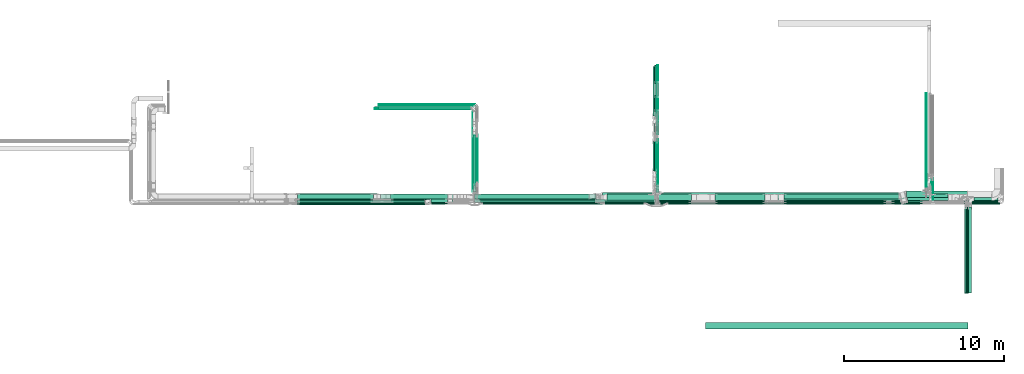
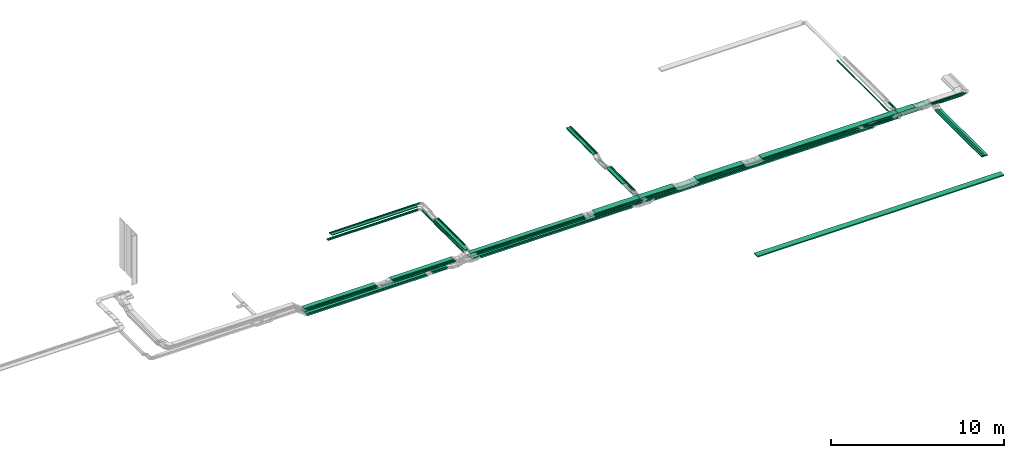
# One storey, part 2 of 27: 76 flow segments.
"""IFC2X3 building model written with IfcOpenShell, lengths in millimetres."""

from ifc_helpers import new_model, entity, si_unit, converted_unit, derived_unit, direction, frame, origin, origin_2d_with_axis, place, context, subcontext, project, spatial, rectangle, extrude, type_object, element, save


model = new_model("IFC2X3")

# Units and contexts
model_context = context("Model", 3, precision=0.01, world=origin(), true_north=direction((6.12303176911189e-17, 1.0)))
body_context = subcontext(model_context, "Body", "Model", "MODEL_VIEW")
ifc_project = project(units=[si_unit("LENGTHUNIT", "METRE", prefix="MILLI"), si_unit("AREAUNIT", "SQUARE_METRE"), si_unit("VOLUMEUNIT", "CUBIC_METRE"), converted_unit("PLANEANGLEUNIT", "DEGREE", entity("IfcRatioMeasure", 0.0174532925199433), si_unit("PLANEANGLEUNIT", "RADIAN"), dimensions=[0, 0, 0, 0, 0, 0, 0]), si_unit("MASSUNIT", "GRAM", prefix="KILO"), derived_unit("MASSDENSITYUNIT", [(si_unit("MASSUNIT", "GRAM", prefix="KILO"), 1), (si_unit("LENGTHUNIT", "METRE"), -3)]), derived_unit("MOMENTOFINERTIAUNIT", [(si_unit("LENGTHUNIT", "METRE"), 4)]), si_unit("TIMEUNIT", "SECOND"), si_unit("FREQUENCYUNIT", "HERTZ"), si_unit("THERMODYNAMICTEMPERATUREUNIT", "DEGREE_CELSIUS"), derived_unit("THERMALTRANSMITTANCEUNIT", [(si_unit("MASSUNIT", "GRAM", prefix="KILO"), 1), (si_unit("THERMODYNAMICTEMPERATUREUNIT", "KELVIN"), -1), (si_unit("TIMEUNIT", "SECOND"), -3)]), derived_unit("VOLUMETRICFLOWRATEUNIT", [(si_unit("LENGTHUNIT", "METRE"), 3), (si_unit("TIMEUNIT", "SECOND"), -1)]), derived_unit("MASSFLOWRATEUNIT", [(si_unit("MASSUNIT", "GRAM", prefix="KILO"), 1), (si_unit("TIMEUNIT", "SECOND"), -1)]), derived_unit("ROTATIONALFREQUENCYUNIT", [(si_unit("TIMEUNIT", "SECOND"), -1)]), si_unit("ELECTRICCURRENTUNIT", "AMPERE"), si_unit("ELECTRICVOLTAGEUNIT", "VOLT"), si_unit("POWERUNIT", "WATT"), si_unit("FORCEUNIT", "NEWTON", prefix="KILO"), si_unit("ILLUMINANCEUNIT", "LUX"), si_unit("LUMINOUSFLUXUNIT", "LUMEN"), si_unit("LUMINOUSINTENSITYUNIT", "CANDELA"), derived_unit("USERDEFINED", [(si_unit("MASSUNIT", "GRAM", prefix="KILO"), -1), (si_unit("LENGTHUNIT", "METRE"), -2), (si_unit("TIMEUNIT", "SECOND"), 3), (si_unit("LUMINOUSFLUXUNIT", "LUMEN"), 1)]), derived_unit("LINEARVELOCITYUNIT", [(si_unit("LENGTHUNIT", "METRE"), 1), (si_unit("TIMEUNIT", "SECOND"), -1)]), si_unit("PRESSUREUNIT", "PASCAL"), derived_unit("USERDEFINED", [(si_unit("LENGTHUNIT", "METRE"), -2), (si_unit("MASSUNIT", "GRAM", prefix="KILO"), 1), (si_unit("TIMEUNIT", "SECOND"), -2)]), derived_unit("LINEARFORCEUNIT", [(si_unit("MASSUNIT", "GRAM", prefix="KILO"), 1), (si_unit("LENGTHUNIT", "METRE"), 1), (si_unit("TIMEUNIT", "SECOND"), -2), (si_unit("LENGTHUNIT", "METRE"), -1)]), derived_unit("PLANARFORCEUNIT", [(si_unit("MASSUNIT", "GRAM", prefix="KILO"), 1), (si_unit("LENGTHUNIT", "METRE"), 1), (si_unit("TIMEUNIT", "SECOND"), -2), (si_unit("LENGTHUNIT", "METRE"), -2)])], contexts=[model_context])

# Site, building, storey
site_placement = place(None, origin())
site = spatial("IfcSite", under=ifc_project, at=site_placement, CompositionType="ELEMENT")
building_placement = place(site_placement, origin())
building = spatial("IfcBuilding", under=site, at=building_placement, CompositionType="ELEMENT")
storey_placement = place(building_placement, origin())
storey = spatial("IfcBuildingStorey", under=building, at=storey_placement, CompositionType="ELEMENT", Elevation=0.0)

# Flow segments
cable_carrier_segment_type = type_object("IfcCableCarrierSegmentType", PredefinedType="CABLETRAYSEGMENT")
flow_segment_1_placement = place(storey_placement, frame((54929.8, 8300.0, 2850.0)))
element("IfcFlowSegment", 1, at=flow_segment_1_placement, inside=storey, type_object=cable_carrier_segment_type, context=body_context, shape_type="SweptSolid", body=[
    extrude(rectangle(XDim=6370.08732356079, YDim=99.9999999999989, at=origin_2d_with_axis()), frame((3185.04, 50.0, 0.0), z_axis=(0.0, 0.0, 1.0), x_axis=(-1.0, 0.0, 0.0)), (0.0, 0.0, 1.0), 49.9999999999995),
])
flow_segment_2_placement = place(storey_placement, frame((47132.17, 8410.0, 2850.0)))
element("IfcFlowSegment", 2, at=flow_segment_2_placement, inside=storey, type_object=cable_carrier_segment_type, context=body_context, shape_type="SweptSolid", body=[
    extrude(rectangle(XDim=2006.37627300281, YDim=100.000000000001, at=origin_2d_with_axis()), frame((1003.19, 50.0, 0.0)), (0.0, 0.0, 1.0), 49.9999999999995),
])
flow_segment_3_placement = place(storey_placement, frame((46843.18, 8520.0, 2850.0)))
element("IfcFlowSegment", 3, at=flow_segment_3_placement, inside=storey, type_object=cable_carrier_segment_type, context=body_context, shape_type="SweptSolid", body=[
    extrude(rectangle(XDim=2295.36020532801, YDim=400.0, at=origin_2d_with_axis()), frame((1147.68, 200.0, 0.0)), (0.0, 0.0, 1.0), 49.9999999999995),
])
flow_segment_4_placement = place(storey_placement, frame((35521.11, 8620.0, 2600.0)))
element("IfcFlowSegment", 4, at=flow_segment_4_placement, inside=storey, type_object=cable_carrier_segment_type, context=body_context, shape_type="SweptSolid", body=[
    extrude(rectangle(XDim=7219.09376803744, YDim=299.999999999999, at=origin_2d_with_axis()), frame((3609.55, 150.0, 0.0)), (0.0, 0.0, 1.0), 100.0),
])
flow_segment_5_placement = place(storey_placement, frame((24527.31, 8570.0, 2600.0)))
element("IfcFlowSegment", 5, at=flow_segment_5_placement, inside=storey, type_object=cable_carrier_segment_type, context=body_context, shape_type="SweptSolid", body=[
    extrude(rectangle(XDim=4983.74700171906, YDim=400.0, at=origin_2d_with_axis()), frame((2491.87, 200.0, 0.0), z_axis=(0.0, 0.0, 1.0), x_axis=(-1.0, 0.0, 0.0)), (0.0, 0.0, 1.0), 100.0),
])
flow_segment_6_placement = place(storey_placement, frame((63792.18, 9272.4, 2600.0)))
element("IfcFlowSegment", 6, at=flow_segment_6_placement, inside=storey, type_object=cable_carrier_segment_type, context=body_context, shape_type="SweptSolid", body=[
    extrude(rectangle(XDim=5940.0, YDim=50.000000000006, at=origin_2d_with_axis()), frame((25.0, 2970.0, 0.0), z_axis=(0.0, 0.0, 1.0), x_axis=(0.0, -1.0, 0.0)), (0.0, 0.0, 1.0), 49.9999999999995),
])
flow_segment_7_placement = place(storey_placement, frame((62655.57, 8400.0, 2600.0)))
element("IfcFlowSegment", 7, at=flow_segment_7_placement, inside=storey, type_object=cable_carrier_segment_type, context=body_context, shape_type="SweptSolid", body=[
    extrude(rectangle(XDim=1271.610584688, YDim=99.9999999999989, at=origin_2d_with_axis()), frame((635.81, 50.0, 0.0)), (0.0, 0.0, 1.0), 100.0),
])
flow_segment_8_placement = place(storey_placement, frame((46898.17, 8410.17, 2600.0)))
element("IfcFlowSegment", 8, at=flow_segment_8_placement, inside=storey, type_object=cable_carrier_segment_type, context=body_context, shape_type="SweptSolid", body=[
    extrude(rectangle(XDim=15296.8333798477, YDim=200.0, at=origin_2d_with_axis()), frame((7648.42, 100.0, 0.0), z_axis=(0.0, 0.0, 1.0), x_axis=(-1.0, 0.0, 0.0)), (0.0, 0.0, 1.0), 100.0),
])
flow_segment_9_placement = place(storey_placement, frame((47045.82, 8620.17, 2600.0)))
element("IfcFlowSegment", 9, at=flow_segment_9_placement, inside=storey, type_object=cable_carrier_segment_type, context=body_context, shape_type="SweptSolid", body=[
    extrude(rectangle(XDim=15060.2769853209, YDim=400.0, at=origin_2d_with_axis()), frame((7530.14, 200.0, 0.0), z_axis=(0.0, 0.0, 1.0), x_axis=(-1.0, 0.0, 0.0)), (0.0, 0.0, 1.0), 100.0),
])
flow_segment_10_placement = place(storey_placement, frame((62577.11, 8724.33, 2600.0)))
element("IfcFlowSegment", 10, at=flow_segment_10_placement, inside=storey, type_object=cable_carrier_segment_type, context=body_context, shape_type="SweptSolid", body=[
    extrude(rectangle(XDim=1239.07857285351, YDim=400.0, at=origin_2d_with_axis()), frame((619.54, 200.0, 0.0)), (0.0, 0.0, 1.0), 100.0),
])
flow_segment_11_placement = place(storey_placement, frame((62638.62, 8514.33, 2600.0)))
element("IfcFlowSegment", 11, at=flow_segment_11_placement, inside=storey, type_object=cable_carrier_segment_type, context=body_context, shape_type="SweptSolid", body=[
    extrude(rectangle(XDim=1418.74753721558, YDim=200.0, at=origin_2d_with_axis()), frame((709.37, 100.0, 0.0)), (0.0, 0.0, 1.0), 100.0),
])
flow_segment_12_placement = place(storey_placement, frame((64058.17, 8514.33, 2600.0)))
element("IfcFlowSegment", 12, at=flow_segment_12_placement, inside=storey, type_object=cable_carrier_segment_type, context=body_context, shape_type="SweptSolid", body=[
    extrude(rectangle(XDim=1550.00000000001, YDim=200.0, at=origin_2d_with_axis()), frame((775.0, 100.0, 0.0)), (0.0, 0.0, 1.0), 100.000000000001),
])
flow_segment_13_placement = place(storey_placement, frame((66145.26, 8410.0, 2850.0)))
element("IfcFlowSegment", 13, at=flow_segment_13_placement, inside=storey, type_object=cable_carrier_segment_type, context=body_context, shape_type="SweptSolid", body=[
    extrude(rectangle(XDim=2159.75324383904, YDim=99.9999999999989, at=origin_2d_with_axis()), frame((1079.88, 50.0, 0.0), z_axis=(0.0, 0.0, 1.0), x_axis=(-1.0, 0.0, 0.0)), (0.0, 0.0, 1.0), 49.9999999999995),
])
flow_segment_14_placement = place(storey_placement, frame((64197.18, 8489.64, 2719.29)))
element("IfcFlowSegment", 14, at=flow_segment_14_placement, inside=storey, type_object=cable_carrier_segment_type, context=body_context, shape_type="SweptSolid", body=[
    extrude(rectangle(XDim=1417.59981973826, YDim=50.000000000006, at=origin_2d_with_axis()), frame((25.0, 708.8, 0.0), z_axis=(0.0, 0.0, 1.0), x_axis=(0.0, -1.0, 0.0)), (0.0, 0.0, 1.0), 50.0000000000005),
])
flow_segment_15_placement = place(storey_placement, frame((64137.18, 8409.33, 2721.0)))
element("IfcFlowSegment", 15, at=flow_segment_15_placement, inside=storey, type_object=cable_carrier_segment_type, context=body_context, shape_type="SweptSolid", body=[
    extrude(rectangle(XDim=1500.75933458754, YDim=50.000000000006, at=origin_2d_with_axis()), frame((25.0, 750.38, 0.0), z_axis=(0.0, 0.0, 1.0), x_axis=(0.0, 1.0, 0.0)), (0.0, 0.0, 1.0), 50.0000000000005),
])
flow_segment_16_placement = place(storey_placement, frame((66145.26, 8300.0, 2850.0)))
element("IfcFlowSegment", 16, at=flow_segment_16_placement, inside=storey, type_object=cable_carrier_segment_type, context=body_context, shape_type="SweptSolid", body=[
    extrude(rectangle(XDim=2269.75324383909, YDim=99.9999999999989, at=origin_2d_with_axis()), frame((1134.88, 50.0, 0.0), z_axis=(0.0, 0.0, 1.0), x_axis=(-1.0, 0.0, 0.0)), (0.0, 0.0, 1.0), 49.9999999999995),
])
flow_segment_17_placement = place(storey_placement, frame((46847.77, 15822.8, 2600.0)))
element("IfcFlowSegment", 17, at=flow_segment_17_placement, inside=storey, type_object=cable_carrier_segment_type, context=body_context, shape_type="SweptSolid", body=[
    extrude(rectangle(XDim=1137.0957799209, YDim=99.9999999999946, at=origin_2d_with_axis()), frame((50.0, 568.55, 0.0), z_axis=(0.0, 0.0, 1.0), x_axis=(0.0, 1.0, 0.0)), (0.0, 0.0, 1.0), 49.9999999999995),
])
for number, where in (
    (18, (47012.18, 13790.77, 2800.0)),
    (19, (46952.18, 13790.77, 2800.0)),
):
    element("IfcFlowSegment", number, at=place(storey_placement, frame(where)), inside=storey, type_object=cable_carrier_segment_type, context=body_context, shape_type="SweptSolid", body=[
        extrude(rectangle(XDim=3099.22880375789, YDim=50.000000000006, at=origin_2d_with_axis()), frame((25.0, 1549.61, 0.0), z_axis=(0.0, 0.0, 1.0), x_axis=(0.0, 1.0, 0.0)), (0.0, 0.0, 1.0), 49.9999999999995),
    ])
flow_segment_18_placement = place(storey_placement, frame((47019.82, 15822.8, 2600.0)))
element("IfcFlowSegment", 20, at=flow_segment_18_placement, inside=storey, type_object=cable_carrier_segment_type, context=body_context, shape_type="SweptSolid", body=[
    extrude(rectangle(XDim=1137.09577991943, YDim=50.000000000006, at=origin_2d_with_axis()), frame((25.0, 568.55, 0.0), z_axis=(0.0, 0.0, 1.0), x_axis=(0.0, 1.0, 0.0)), (0.0, 0.0, 1.0), 50.0000000000005),
])
flow_segment_19_placement = place(storey_placement, frame((32876.65, 8410.17, 2600.0)))
element("IfcFlowSegment", 21, at=flow_segment_19_placement, inside=storey, type_object=cable_carrier_segment_type, context=body_context, shape_type="SweptSolid", body=[
    extrude(rectangle(XDim=1039.99874618809, YDim=200.0, at=origin_2d_with_axis()), frame((520.0, 100.0, 0.0)), (0.0, 0.0, 1.0), 100.000000000001),
])
flow_segment_20_placement = place(storey_placement, frame((43583.82, 8620.17, 2600.0)))
element("IfcFlowSegment", 22, at=flow_segment_20_placement, inside=storey, type_object=cable_carrier_segment_type, context=body_context, shape_type="SweptSolid", body=[
    extrude(rectangle(XDim=3460.0, YDim=400.0, at=origin_2d_with_axis()), frame((1730.0, 200.0, 0.0), z_axis=(0.0, 0.0, 1.0), x_axis=(-1.0, 0.0, 0.0)), (0.0, 0.0, 1.0), 100.0),
])
flow_segment_21_placement = place(storey_placement, frame((47688.79, 8300.17, 2600.0)))
element("IfcFlowSegment", 23, at=flow_segment_21_placement, inside=storey, type_object=cable_carrier_segment_type, context=body_context, shape_type="SweptSolid", body=[
    extrude(rectangle(XDim=14552.3620361267, YDim=100.000000000001, at=origin_2d_with_axis()), frame((7276.18, 50.0, 0.0)), (0.0, 0.0, 1.0), 100.0),
])
flow_segment_22_placement = place(storey_placement, frame((46742.18, 13790.77, 2800.0)))
element("IfcFlowSegment", 24, at=flow_segment_22_placement, inside=storey, type_object=cable_carrier_segment_type, context=body_context, shape_type="SweptSolid", body=[
    extrude(rectangle(XDim=3099.2288037579, YDim=200.000000000007, at=origin_2d_with_axis()), frame((100.0, 1549.61, 0.0), z_axis=(0.0, 0.0, 1.0), x_axis=(0.0, 1.0, 0.0)), (0.0, 0.0, 1.0), 50.0000000000005),
])
flow_segment_23_placement = place(storey_placement, frame((43861.18, 8520.0, 2850.0)))
element("IfcFlowSegment", 25, at=flow_segment_23_placement, inside=storey, type_object=cable_carrier_segment_type, context=body_context, shape_type="SweptSolid", body=[
    extrude(rectangle(XDim=2980.00000000002, YDim=400.0, at=origin_2d_with_axis()), frame((1490.0, 200.0, 0.0), z_axis=(0.0, 0.0, 1.0), x_axis=(-1.0, 0.0, 0.0)), (0.0, 0.0, 1.0), 49.9999999999995),
])
flow_segment_24_placement = place(storey_placement, frame((35555.11, 9465.53, 2600.0)))
element("IfcFlowSegment", 26, at=flow_segment_24_placement, inside=storey, type_object=cable_carrier_segment_type, context=body_context, shape_type="SweptSolid", body=[
    extrude(rectangle(XDim=4668.46927962027, YDim=100.000000000003, at=origin_2d_with_axis()), frame((50.0, 2334.23, 0.0), z_axis=(0.0, 0.0, 1.0), x_axis=(0.0, 1.0, 0.0)), (0.0, 0.0, 1.0), 49.9999999999995),
])
flow_segment_25_placement = place(storey_placement, frame((35767.46, 9536.72, 2850.0)))
element("IfcFlowSegment", 27, at=flow_segment_25_placement, inside=storey, type_object=cable_carrier_segment_type, context=body_context, shape_type="SweptSolid", body=[
    extrude(rectangle(XDim=3095.56319386164, YDim=49.9999999999973, at=origin_2d_with_axis()), frame((25.0, 1547.78, 0.0), z_axis=(0.0, 0.0, 1.0), x_axis=(0.0, 1.0, 0.0)), (0.0, 0.0, 1.0), 50.0000000000005),
])
flow_segment_26_placement = place(storey_placement, frame((35707.46, 9536.72, 2850.0)))
element("IfcFlowSegment", 28, at=flow_segment_26_placement, inside=storey, type_object=cable_carrier_segment_type, context=body_context, shape_type="SweptSolid", body=[
    extrude(rectangle(XDim=3095.5631938618, YDim=49.9999999999973, at=origin_2d_with_axis()), frame((25.0, 1547.78, 0.0), z_axis=(0.0, 0.0, 1.0), x_axis=(0.0, -1.0, 0.0)), (0.0, 0.0, 1.0), 50.0000000000005),
])
flow_segment_27_placement = place(storey_placement, frame((35495.11, 9070.0, 2850.0)))
element("IfcFlowSegment", 29, at=flow_segment_27_placement, inside=storey, type_object=cable_carrier_segment_type, context=body_context, shape_type="SweptSolid", body=[
    extrude(rectangle(XDim=3562.28653481264, YDim=199.999999999998, at=origin_2d_with_axis()), frame((100.0, 1781.14, 0.0), z_axis=(0.0, 0.0, 1.0), x_axis=(0.0, 1.0, 0.0)), (0.0, 0.0, 1.0), 50.0000000000005),
])
flow_segment_28_placement = place(storey_placement, frame((29362.46, 14285.0, 2600.0)))
element("IfcFlowSegment", 30, at=flow_segment_28_placement, inside=storey, type_object=cable_carrier_segment_type, context=body_context, shape_type="SweptSolid", body=[
    extrude(rectangle(XDim=6041.64888445136, YDim=99.9999999999989, at=origin_2d_with_axis()), frame((3020.82, 50.0, 0.0), z_axis=(0.0, 0.0, 1.0), x_axis=(-1.0, 0.0, 0.0)), (0.0, 0.0, 1.0), 49.9999999999995),
])
flow_segment_29_placement = place(storey_placement, frame((35495.11, 9060.0, 2600.0)))
element("IfcFlowSegment", 31, at=flow_segment_29_placement, inside=storey, type_object=cable_carrier_segment_type, context=body_context, shape_type="SweptSolid", body=[
    extrude(rectangle(XDim=5013.99993893918, YDim=49.9999999999973, at=origin_2d_with_axis()), frame((25.0, 2507.0, 0.0), z_axis=(0.0, 0.0, 1.0), x_axis=(0.0, 1.0, 0.0)), (0.0, 0.0, 1.0), 50.0000000000005),
])
flow_segment_30_placement = place(storey_placement, frame((29362.46, 14225.0, 2600.0)))
element("IfcFlowSegment", 32, at=flow_segment_30_placement, inside=storey, type_object=cable_carrier_segment_type, context=body_context, shape_type="SweptSolid", body=[
    extrude(rectangle(XDim=5981.64888445141, YDim=50.0000000000016, at=origin_2d_with_axis()), frame((2990.82, 25.0, 0.0), z_axis=(0.0, 0.0, 1.0), x_axis=(-1.0, 0.0, 0.0)), (0.0, 0.0, 1.0), 49.9999999999995),
])
flow_segment_31_placement = place(storey_placement, frame((29612.46, 14495.0, 2850.0)))
element("IfcFlowSegment", 33, at=flow_segment_31_placement, inside=storey, type_object=cable_carrier_segment_type, context=body_context, shape_type="SweptSolid", body=[
    extrude(rectangle(XDim=6025.00000000003, YDim=50.0000000000016, at=origin_2d_with_axis()), frame((3012.5, 25.0, 0.0), z_axis=(0.0, 0.0, 1.0), x_axis=(-1.0, 0.0, 0.0)), (0.0, 0.0, 1.0), 50.0000000000005),
])
flow_segment_32_placement = place(storey_placement, frame((29612.46, 14435.0, 2850.0)))
element("IfcFlowSegment", 34, at=flow_segment_32_placement, inside=storey, type_object=cable_carrier_segment_type, context=body_context, shape_type="SweptSolid", body=[
    extrude(rectangle(XDim=5944.00000000003, YDim=50.0000000000016, at=origin_2d_with_axis()), frame((2972.0, 25.0, 0.0), z_axis=(0.0, 0.0, 1.0), x_axis=(-1.0, 0.0, 0.0)), (0.0, 0.0, 1.0), 50.0000000000005),
])
flow_segment_33_placement = place(storey_placement, frame((29612.46, 14225.0, 2850.0)))
element("IfcFlowSegment", 35, at=flow_segment_33_placement, inside=storey, type_object=cable_carrier_segment_type, context=body_context, shape_type="SweptSolid", body=[
    extrude(rectangle(XDim=5731.6488844514, YDim=200.000000000002, at=origin_2d_with_axis()), frame((2865.82, 100.0, 0.0), z_axis=(0.0, 0.0, 1.0), x_axis=(-1.0, 0.0, 0.0)), (0.0, 0.0, 1.0), 49.9999999999995),
])
flow_segment_34_placement = place(storey_placement, frame((30367.01, 8620.0, 2850.0)))
element("IfcFlowSegment", 36, at=flow_segment_34_placement, inside=storey, type_object=cable_carrier_segment_type, context=body_context, shape_type="SweptSolid", body=[
    extrude(rectangle(XDim=4130.35917387728, YDim=300.000000000001, at=origin_2d_with_axis()), frame((2065.18, 150.0, 0.0)), (0.0, 0.0, 1.0), 49.9999999999995),
])
flow_segment_35_placement = place(storey_placement, frame((30367.01, 8510.0, 2850.0)))
element("IfcFlowSegment", 37, at=flow_segment_35_placement, inside=storey, type_object=cable_carrier_segment_type, context=body_context, shape_type="SweptSolid", body=[
    extrude(rectangle(XDim=4130.35917387756, YDim=100.000000000001, at=origin_2d_with_axis()), frame((2065.18, 50.0, 0.0), z_axis=(0.0, 0.0, 1.0), x_axis=(-1.0, 0.0, 0.0)), (0.0, 0.0, 1.0), 50.0000000000011),
])
flow_segment_36_placement = place(storey_placement, frame((30367.01, 8400.0, 2850.0)))
element("IfcFlowSegment", 38, at=flow_segment_36_placement, inside=storey, type_object=cable_carrier_segment_type, context=body_context, shape_type="SweptSolid", body=[
    extrude(rectangle(XDim=4130.35917387749, YDim=100.000000000001, at=origin_2d_with_axis()), frame((2065.18, 50.0, 0.0), z_axis=(0.0, 0.0, 1.0), x_axis=(-1.0, 0.0, 0.0)), (0.0, 0.0, 1.0), 49.9999999999995),
])
flow_segment_37_placement = place(storey_placement, frame((50627.81, 8410.0, 2850.0)))
element("IfcFlowSegment", 39, at=flow_segment_37_placement, inside=storey, type_object=cable_carrier_segment_type, context=body_context, shape_type="SweptSolid", body=[
    extrude(rectangle(XDim=3111.50022738776, YDim=99.9999999999989, at=origin_2d_with_axis()), frame((1555.75, 50.0, 0.0), z_axis=(7.08942723260704e-08, 0.0, 1.0), x_axis=(-1.0, 0.0, 7.08942723260704e-08)), (0.0, 0.0, 1.0), 49.9999999999996),
])
flow_segment_38_placement = place(storey_placement, frame((47199.82, 8300.0, 2850.0)))
element("IfcFlowSegment", 40, at=flow_segment_38_placement, inside=storey, type_object=cable_carrier_segment_type, context=body_context, shape_type="SweptSolid", body=[
    extrude(rectangle(XDim=1938.72426175145, YDim=99.9999999999989, at=origin_2d_with_axis()), frame((969.36, 50.0, 0.0)), (0.0, 0.0, 1.0), 49.9999999999995),
])
flow_segment_39_placement = place(storey_placement, frame((47019.82, 9060.0, 2600.0)))
element("IfcFlowSegment", 41, at=flow_segment_39_placement, inside=storey, type_object=cable_carrier_segment_type, context=body_context, shape_type="SweptSolid", body=[
    extrude(rectangle(XDim=3286.61163187284, YDim=50.000000000006, at=origin_2d_with_axis()), frame((25.0, 1643.31, 0.0), z_axis=(0.0, 0.0, 1.0), x_axis=(0.0, -1.0, 0.0)), (0.0, 0.0, 1.0), 49.9999999999995),
])
flow_segment_40_placement = place(storey_placement, frame((46847.77, 9444.27, 2600.0)))
element("IfcFlowSegment", 42, at=flow_segment_40_placement, inside=storey, type_object=cable_carrier_segment_type, context=body_context, shape_type="SweptSolid", body=[
    extrude(rectangle(XDim=2902.34103191558, YDim=99.9999999999946, at=origin_2d_with_axis()), frame((50.0, 1451.17, 0.0), z_axis=(0.0, 0.0, 1.0), x_axis=(0.0, 1.0, 0.0)), (0.0, 0.0, 1.0), 49.9999999999995),
])
flow_segment_41_placement = place(storey_placement, frame((47019.82, 12660.0, 2450.0)))
element("IfcFlowSegment", 43, at=flow_segment_41_placement, inside=storey, type_object=cable_carrier_segment_type, context=body_context, shape_type="SweptSolid", body=[
    extrude(rectangle(XDim=1103.60147622474, YDim=50.000000000006, at=origin_2d_with_axis()), frame((25.0, 551.8, 0.0), z_axis=(0.0, 0.0, 1.0), x_axis=(0.0, -1.0, 0.0)), (0.0, 0.0, 1.0), 50.0000000000005),
])
flow_segment_42_placement = place(storey_placement, frame((46847.77, 12660.0, 2450.0)))
element("IfcFlowSegment", 44, at=flow_segment_42_placement, inside=storey, type_object=cable_carrier_segment_type, context=body_context, shape_type="SweptSolid", body=[
    extrude(rectangle(XDim=1103.60147622524, YDim=99.9999999999946, at=origin_2d_with_axis()), frame((50.0, 551.8, 0.0), z_axis=(0.0, 0.0, 1.0), x_axis=(0.0, -1.0, 0.0)), (0.0, 0.0, 1.0), 50.0000000000005),
])
flow_segment_43_placement = place(storey_placement, frame((47020.12, 9428.95, 2800.0)))
element("IfcFlowSegment", 45, at=flow_segment_43_placement, inside=storey, type_object=cable_carrier_segment_type, context=body_context, shape_type="SweptSolid", body=[
    extrude(rectangle(XDim=2803.04946350503, YDim=50.000000000006, at=origin_2d_with_axis()), frame((25.0, 1401.52, 0.0), z_axis=(0.0, 0.0, 1.0), x_axis=(0.0, 1.0, 0.0)), (0.0, 0.0, 1.0), 49.9999999999995),
])
flow_segment_44_placement = place(storey_placement, frame((46959.82, 9428.95, 2800.0)))
element("IfcFlowSegment", 46, at=flow_segment_44_placement, inside=storey, type_object=cable_carrier_segment_type, context=body_context, shape_type="SweptSolid", body=[
    extrude(rectangle(XDim=2795.15412443013, YDim=50.000000000006, at=origin_2d_with_axis()), frame((25.0, 1397.58, 0.0), z_axis=(0.0, 0.0, 1.0), x_axis=(0.0, 1.0, 0.0)), (0.0, 0.0, 1.0), 50.0000000000005),
])
flow_segment_45_placement = place(storey_placement, frame((46742.18, 10356.95, 2800.0)))
element("IfcFlowSegment", 47, at=flow_segment_45_placement, inside=storey, type_object=cable_carrier_segment_type, context=body_context, shape_type="SweptSolid", body=[
    extrude(rectangle(XDim=1867.15043378258, YDim=200.000000000007, at=origin_2d_with_axis()), frame((100.0, 933.58, 0.0), z_axis=(0.0, 0.0, 1.0), x_axis=(0.0, -1.0, 0.0)), (0.0, 0.0, 1.0), 50.0000000000005),
])
flow_segment_46_placement = place(storey_placement, frame((35947.6, 8400.0, 2850.0)))
element("IfcFlowSegment", 48, at=flow_segment_46_placement, inside=storey, type_object=cable_carrier_segment_type, context=body_context, shape_type="SweptSolid", body=[
    extrude(rectangle(XDim=7185.91505426564, YDim=99.9999999999989, at=origin_2d_with_axis()), frame((3592.96, 50.0, 0.0), z_axis=(0.0, 0.0, 1.0), x_axis=(-1.0, 0.0, 0.0)), (0.0, 0.0, 1.0), 49.9999999999995),
])
flow_segment_47_placement = place(storey_placement, frame((36110.1, 8290.0, 2600.0)))
element("IfcFlowSegment", 49, at=flow_segment_47_placement, inside=storey, type_object=cable_carrier_segment_type, context=body_context, shape_type="SweptSolid", body=[
    extrude(rectangle(XDim=10071.3033738979, YDim=99.9999999999989, at=origin_2d_with_axis()), frame((5035.65, 50.0, 0.0), z_axis=(0.0, 0.0, 1.0), x_axis=(-1.0, 0.0, 0.0)), (0.0, 0.0, 1.0), 100.0),
])
flow_segment_48_placement = place(storey_placement, frame((35887.44, 8510.0, 2850.0)))
element("IfcFlowSegment", 50, at=flow_segment_48_placement, inside=storey, type_object=cable_carrier_segment_type, context=body_context, shape_type="SweptSolid", body=[
    extrude(rectangle(XDim=7246.06706551713, YDim=99.9999999999989, at=origin_2d_with_axis()), frame((3623.03, 50.0, 0.0), z_axis=(0.0, 0.0, 1.0), x_axis=(-1.0, 0.0, 0.0)), (0.0, 0.0, 1.0), 49.9999999999995),
])
flow_segment_49_placement = place(storey_placement, frame((24527.31, 8250.0, 2600.0)))
element("IfcFlowSegment", 51, at=flow_segment_49_placement, inside=storey, type_object=cable_carrier_segment_type, context=body_context, shape_type="SweptSolid", body=[
    extrude(rectangle(XDim=7986.3573272726, YDim=99.9999999999989, at=origin_2d_with_axis()), frame((3993.18, 50.0, 0.0), z_axis=(0.0, 0.0, 1.0), x_axis=(-1.0, 0.0, 0.0)), (0.0, 0.0, 1.0), 100.0),
])
flow_segment_50_placement = place(storey_placement, frame((29741.06, 8620.0, 2600.0)))
element("IfcFlowSegment", 52, at=flow_segment_50_placement, inside=storey, type_object=cable_carrier_segment_type, context=body_context, shape_type="SweptSolid", body=[
    extrude(rectangle(XDim=4175.58651434346, YDim=300.000000000001, at=origin_2d_with_axis()), frame((2087.79, 150.0, 0.0)), (0.0, 0.0, 1.0), 100.0),
])
flow_segment_51_placement = place(storey_placement, frame((24545.22, 8400.0, 2850.0)))
element("IfcFlowSegment", 53, at=flow_segment_51_placement, inside=storey, type_object=cable_carrier_segment_type, context=body_context, shape_type="SweptSolid", body=[
    extrude(rectangle(XDim=4741.45457153696, YDim=100.000000000001, at=origin_2d_with_axis()), frame((2370.73, 50.0, 0.0)), (0.0, 0.0, 1.0), 49.9999999999995),
])
flow_segment_52_placement = place(storey_placement, frame((24545.22, 8510.0, 2850.0)))
element("IfcFlowSegment", 54, at=flow_segment_52_placement, inside=storey, type_object=cable_carrier_segment_type, context=body_context, shape_type="SweptSolid", body=[
    extrude(rectangle(XDim=4741.45457153696, YDim=100.000000000001, at=origin_2d_with_axis()), frame((2370.73, 50.0, 0.0)), (0.0, 0.0, 1.0), 50.0000000000005),
])
flow_segment_53_placement = place(storey_placement, frame((24545.22, 8620.0, 2850.0)))
element("IfcFlowSegment", 55, at=flow_segment_53_placement, inside=storey, type_object=cable_carrier_segment_type, context=body_context, shape_type="SweptSolid", body=[
    extrude(rectangle(XDim=4741.45457153684, YDim=299.999999999999, at=origin_2d_with_axis()), frame((2370.73, 150.0, 0.0), z_axis=(0.0, 0.0, 1.0), x_axis=(-1.0, 0.0, 0.0)), (0.0, 0.0, 1.0), 50.0000000000005),
])
flow_segment_54_placement = place(storey_placement, frame((61658.78, 8410.0, 2750.0)))
element("IfcFlowSegment", 56, at=flow_segment_54_placement, inside=storey, type_object=cable_carrier_segment_type, context=body_context, shape_type="SweptSolid", body=[
    extrude(rectangle(XDim=1911.50856462211, YDim=100.000000000001, at=origin_2d_with_axis()), frame((955.75, 50.0, 0.0)), (0.0, 0.0, 1.0), 49.9999999999995),
])
flow_segment_55_placement = place(storey_placement, frame((61658.78, 8300.0, 2750.0)))
element("IfcFlowSegment", 57, at=flow_segment_55_placement, inside=storey, type_object=cable_carrier_segment_type, context=body_context, shape_type="SweptSolid", body=[
    extrude(rectangle(XDim=1911.50856462196, YDim=99.9999999999989, at=origin_2d_with_axis()), frame((955.75, 50.0, 0.0)), (0.0, 0.0, 1.0), 50.0000000000005),
])
flow_segment_56_placement = place(storey_placement, frame((54929.8, 8410.0, 2850.0)))
element("IfcFlowSegment", 58, at=flow_segment_56_placement, inside=storey, type_object=cable_carrier_segment_type, context=body_context, shape_type="SweptSolid", body=[
    extrude(rectangle(XDim=6370.08732356081, YDim=100.000000000001, at=origin_2d_with_axis()), frame((3185.04, 50.0, 0.0), z_axis=(0.0, 0.0, 1.0), x_axis=(-1.0, 0.0, 0.0)), (0.0, 0.0, 1.0), 49.9999999999995),
])
flow_segment_57_placement = place(storey_placement, frame((50627.81, 8300.0, 2850.0)))
element("IfcFlowSegment", 59, at=flow_segment_57_placement, inside=storey, type_object=cable_carrier_segment_type, context=body_context, shape_type="SweptSolid", body=[
    extrude(rectangle(XDim=3111.4986535571, YDim=100.000000000001, at=origin_2d_with_axis()), frame((1555.75, 50.0, 0.0), z_axis=(0.0, 0.0, 1.0), x_axis=(-1.0, 0.0, 0.0)), (0.0, 0.0, 1.0), 49.9999999999995),
])
flow_segment_58_placement = place(storey_placement, frame((50627.81, 8520.0, 2850.0)))
element("IfcFlowSegment", 60, at=flow_segment_58_placement, inside=storey, type_object=cable_carrier_segment_type, context=body_context, shape_type="SweptSolid", body=[
    extrude(rectangle(XDim=3111.49865355683, YDim=400.0, at=origin_2d_with_axis()), frame((1555.75, 200.0, 0.0), z_axis=(0.0, 0.0, 1.0), x_axis=(-1.0, 0.0, 0.0)), (0.0, 0.0, 1.0), 50.0000000000005),
])
flow_segment_59_placement = place(storey_placement, frame((47019.82, 14076.99, 2600.0)))
element("IfcFlowSegment", 61, at=flow_segment_59_placement, inside=storey, type_object=cable_carrier_segment_type, context=body_context, shape_type="SweptSolid", body=[
    extrude(rectangle(XDim=1028.29671107794, YDim=50.000000000006, at=origin_2d_with_axis()), frame((25.0, 514.15, 0.0), z_axis=(0.0, 0.0, 1.0), x_axis=(0.0, 1.0, 0.0)), (0.0, 0.0, 1.0), 49.9999999999995),
])
flow_segment_60_placement = place(storey_placement, frame((46847.77, 14076.99, 2600.0)))
element("IfcFlowSegment", 62, at=flow_segment_60_placement, inside=storey, type_object=cable_carrier_segment_type, context=body_context, shape_type="SweptSolid", body=[
    extrude(rectangle(XDim=1028.29671107504, YDim=99.9999999999946, at=origin_2d_with_axis()), frame((50.0, 514.15, 0.0), z_axis=(0.0, 0.0, 1.0), x_axis=(0.0, 1.0, 0.0)), (0.0, 0.0, 1.0), 49.9999999999995),
])
flow_segment_61_placement = place(storey_placement, frame((35596.11, 8620.0, 2850.0)))
element("IfcFlowSegment", 63, at=flow_segment_61_placement, inside=storey, type_object=cable_carrier_segment_type, context=body_context, shape_type="SweptSolid", body=[
    extrude(rectangle(XDim=7580.94324085374, YDim=300.000000000001, at=origin_2d_with_axis()), frame((3790.47, 150.0, 0.0)), (0.0, 0.0, 1.0), 50.0000000000005),
])
flow_segment_62_placement = place(storey_placement, frame((43737.01, 8410.0, 2850.0)))
element("IfcFlowSegment", 64, at=flow_segment_62_placement, inside=storey, type_object=cable_carrier_segment_type, context=body_context, shape_type="SweptSolid", body=[
    extrude(rectangle(XDim=3085.15920483105, YDim=99.9999999999989, at=origin_2d_with_axis()), frame((1542.58, 50.0, 0.0)), (0.0, 0.0, 1.0), 49.9999999999995),
])
flow_segment_63_placement = place(storey_placement, frame((43737.01, 8300.0, 2850.0)))
element("IfcFlowSegment", 65, at=flow_segment_63_placement, inside=storey, type_object=cable_carrier_segment_type, context=body_context, shape_type="SweptSolid", body=[
    extrude(rectangle(XDim=3152.81121608253, YDim=99.9999999999989, at=origin_2d_with_axis()), frame((1576.41, 50.0, 0.0)), (0.0, 0.0, 1.0), 49.9999999999995),
])
flow_segment_64_placement = place(storey_placement, frame((35605.51, 8410.17, 2600.0)))
element("IfcFlowSegment", 66, at=flow_segment_64_placement, inside=storey, type_object=cable_carrier_segment_type, context=body_context, shape_type="SweptSolid", body=[
    extrude(rectangle(XDim=11291.8611899384, YDim=200.0, at=origin_2d_with_axis()), frame((5645.93, 100.0, 0.0), z_axis=(0.0, 0.0, 1.0), x_axis=(-1.0, 0.0, 0.0)), (0.0, 0.0, 1.0), 100.0),
])
flow_segment_65_placement = place(storey_placement, frame((32890.25, 8290.0, 2600.0)))
element("IfcFlowSegment", 67, at=flow_segment_65_placement, inside=storey, type_object=cable_carrier_segment_type, context=body_context, shape_type="SweptSolid", body=[
    extrude(rectangle(XDim=1026.40013799145, YDim=100.000000000001, at=origin_2d_with_axis()), frame((513.2, 50.0, 0.0), z_axis=(0.0, 0.0, 1.0), x_axis=(-1.0, 0.0, 0.0)), (0.0, 0.0, 1.0), 100.0),
])
flow_segment_66_placement = place(storey_placement, frame((24527.31, 8360.0, 2600.0)))
element("IfcFlowSegment", 68, at=flow_segment_66_placement, inside=storey, type_object=cable_carrier_segment_type, context=body_context, shape_type="SweptSolid", body=[
    extrude(rectangle(XDim=7959.95593546928, YDim=200.0, at=origin_2d_with_axis()), frame((3979.98, 100.0, 0.0), z_axis=(0.0, 0.0, 1.0), x_axis=(-1.0, 0.0, 0.0)), (0.0, 0.0, 1.0), 100.0),
])
flow_segment_67_placement = place(storey_placement, frame((66225.0, 2744.13, 2500.0)))
element("IfcFlowSegment", 69, at=flow_segment_67_placement, inside=storey, type_object=cable_carrier_segment_type, context=body_context, shape_type="SweptSolid", body=[
    extrude(rectangle(XDim=5385.36941381057, YDim=99.9999999999946, at=origin_2d_with_axis()), frame((50.0, 2692.68, 0.0), z_axis=(0.0, 0.0, 1.0), x_axis=(0.0, -1.0, 0.0)), (0.0, 0.0, 1.0), 100.0),
])
flow_segment_68_placement = place(storey_placement, frame((63818.18, 8724.33, 2600.0)))
element("IfcFlowSegment", 70, at=flow_segment_68_placement, inside=storey, type_object=cable_carrier_segment_type, context=body_context, shape_type="SweptSolid", body=[
    extrude(rectangle(XDim=2565.81236603563, YDim=400.0, at=origin_2d_with_axis()), frame((1282.91, 200.0, 0.0)), (0.0, 0.0, 1.0), 100.0),
])
flow_segment_69_placement = place(storey_placement, frame((66335.0, 2744.13, 2500.0)))
element("IfcFlowSegment", 71, at=flow_segment_69_placement, inside=storey, type_object=cable_carrier_segment_type, context=body_context, shape_type="SweptSolid", body=[
    extrude(rectangle(XDim=5385.36941381055, YDim=99.9999999999946, at=origin_2d_with_axis()), frame((50.0, 2692.68, 0.0), z_axis=(0.0, 0.0, 1.0), x_axis=(0.0, -1.0, 0.0)), (0.0, 0.0, 1.0), 100.0),
])
flow_segment_70_placement = place(storey_placement, frame((66796.0, 8514.33, 2600.0)))
element("IfcFlowSegment", 72, at=flow_segment_70_placement, inside=storey, type_object=cable_carrier_segment_type, context=body_context, shape_type="SweptSolid", body=[
    extrude(rectangle(XDim=1509.01217238576, YDim=200.0, at=origin_2d_with_axis()), frame((754.51, 100.0, 0.0), z_axis=(0.0, 0.0, 1.0), x_axis=(-1.0, 0.0, 0.0)), (0.0, 0.0, 1.0), 50.0000000000005),
])
flow_segment_71_placement = place(storey_placement, frame((66445.0, 2744.13, 2500.0)))
element("IfcFlowSegment", 73, at=flow_segment_71_placement, inside=storey, type_object=cable_carrier_segment_type, context=body_context, shape_type="SweptSolid", body=[
    extrude(rectangle(XDim=5370.73706607355, YDim=200.000000000007, at=origin_2d_with_axis()), frame((100.0, 2685.37, 0.0), z_axis=(0.0, 0.0, 1.0), x_axis=(0.0, -1.0, 0.0)), (0.0, 0.0, 1.0), 50.0000000000005),
])
flow_segment_72_placement = place(storey_placement, frame((54929.8, 8520.0, 2850.0)))
element("IfcFlowSegment", 74, at=flow_segment_72_placement, inside=storey, type_object=cable_carrier_segment_type, context=body_context, shape_type="SweptSolid", body=[
    extrude(rectangle(XDim=9071.38850742713, YDim=400.0, at=origin_2d_with_axis()), frame((4535.69, 200.0, 0.0), z_axis=(0.0, 0.0, 1.0), x_axis=(-1.0, 0.0, 0.0)), (0.0, 0.0, 1.0), 49.9999999999995),
])
flow_segment_73_placement = place(storey_placement, frame((64003.18, 8520.0, 2850.0)))
element("IfcFlowSegment", 75, at=flow_segment_73_placement, inside=storey, type_object=cable_carrier_segment_type, context=body_context, shape_type="SweptSolid", body=[
    extrude(rectangle(XDim=1167.15792122105, YDim=400.0, at=origin_2d_with_axis()), frame((583.58, 200.0, 0.0)), (0.0, 0.0, 1.0), 49.9999999999995),
])
flow_segment_74_placement = place(storey_placement, frame((50020.0, 500.0, 2500.0)))
element("IfcFlowSegment", 76, at=flow_segment_74_placement, inside=storey, type_object=cable_carrier_segment_type, context=body_context, shape_type="SweptSolid", body=[
    extrude(rectangle(XDim=16400.0, YDim=400.0, at=origin_2d_with_axis()), frame((8200.0, 200.0, 0.0), z_axis=(0.0, 0.0, 1.0), x_axis=(-1.0, 0.0, 0.0)), (0.0, 0.0, 1.0), 80.0000000000002),
])

save(model, "model.ifc")
